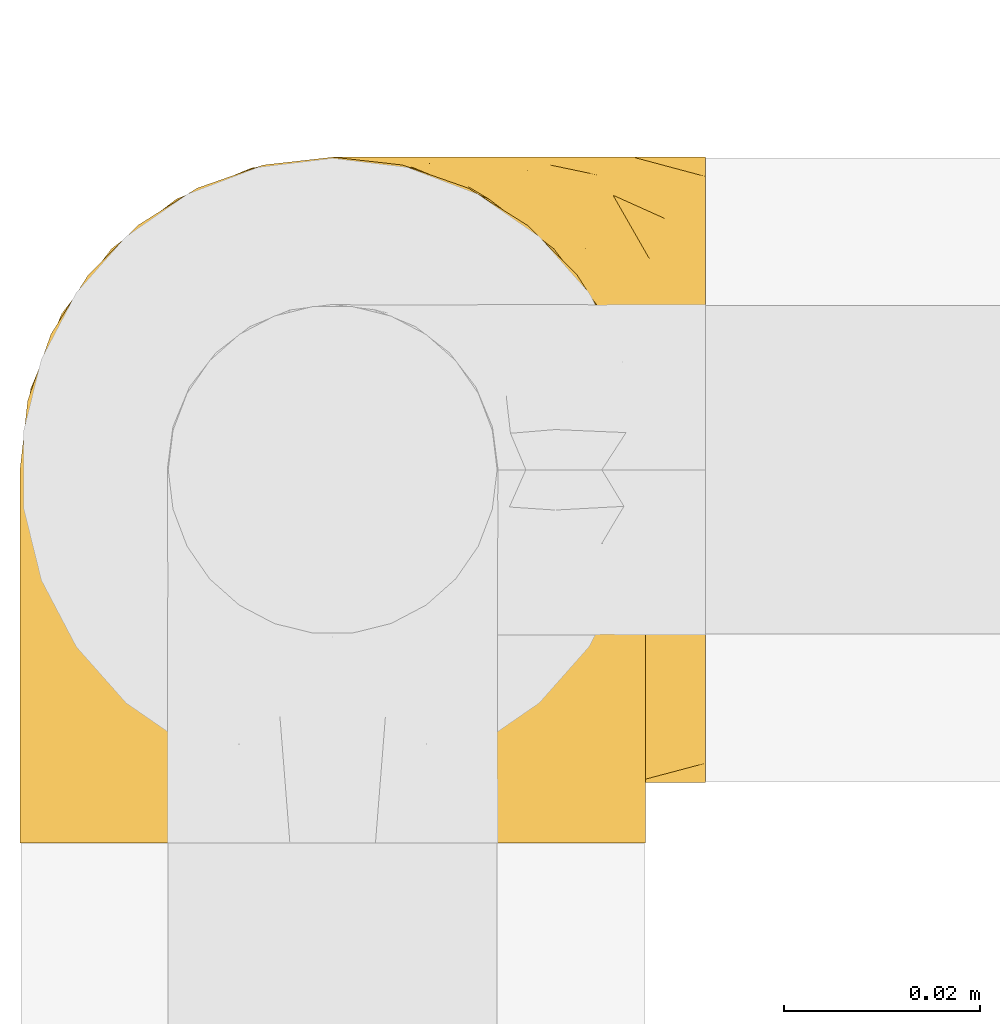
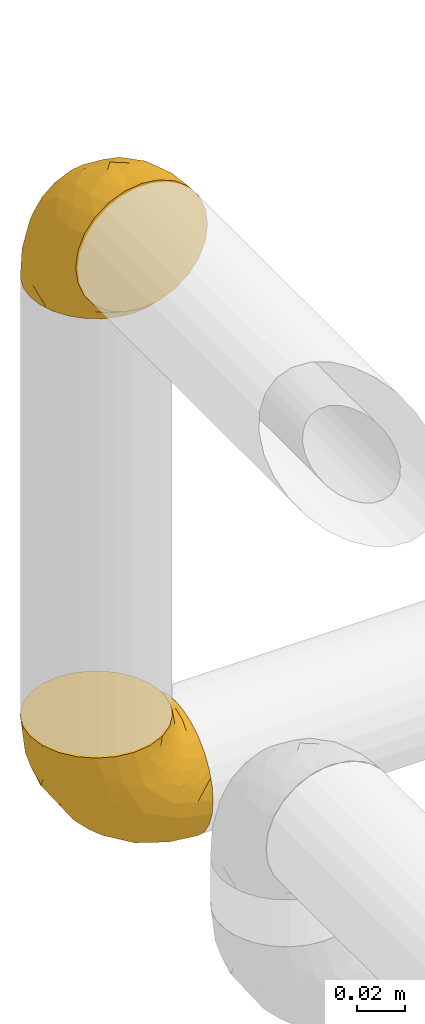
# One storey, part 11 of 39: 2 coverings.
"""IFC2X3 building model written with IfcOpenShell, lengths in millimetres."""

from ifc_helpers import new_model, entity, si_unit, converted_unit, derived_unit, direction, frame, origin, place, context, subcontext, project, spatial, faceted_brep, element, save


model = new_model("IFC2X3")

# Units and contexts
model_context = context("Model", 3, precision=0.01, world=origin(), true_north=direction((6.12303176911189e-17, 1.0)))
body_context = subcontext(model_context, "Body", "Model", "MODEL_VIEW")
ifc_project = project(units=[si_unit("LENGTHUNIT", "METRE", prefix="MILLI"), si_unit("AREAUNIT", "SQUARE_METRE"), si_unit("VOLUMEUNIT", "CUBIC_METRE"), converted_unit("PLANEANGLEUNIT", "DEGREE", entity("IfcRatioMeasure", 0.0174532925199433), si_unit("PLANEANGLEUNIT", "RADIAN"), dimensions=[0, 0, 0, 0, 0, 0, 0]), si_unit("MASSUNIT", "GRAM", prefix="KILO"), derived_unit("MASSDENSITYUNIT", [(si_unit("MASSUNIT", "GRAM", prefix="KILO"), 1), (si_unit("LENGTHUNIT", "METRE"), -3)]), derived_unit("MOMENTOFINERTIAUNIT", [(si_unit("LENGTHUNIT", "METRE"), 4)]), si_unit("TIMEUNIT", "SECOND"), si_unit("FREQUENCYUNIT", "HERTZ"), si_unit("THERMODYNAMICTEMPERATUREUNIT", "DEGREE_CELSIUS"), derived_unit("THERMALTRANSMITTANCEUNIT", [(si_unit("MASSUNIT", "GRAM", prefix="KILO"), 1), (si_unit("THERMODYNAMICTEMPERATUREUNIT", "KELVIN"), -1), (si_unit("TIMEUNIT", "SECOND"), -3)]), derived_unit("VOLUMETRICFLOWRATEUNIT", [(si_unit("LENGTHUNIT", "METRE"), 3), (si_unit("TIMEUNIT", "SECOND"), -1)]), derived_unit("MASSFLOWRATEUNIT", [(si_unit("MASSUNIT", "GRAM", prefix="KILO"), 1), (si_unit("TIMEUNIT", "SECOND"), -1)]), derived_unit("ROTATIONALFREQUENCYUNIT", [(si_unit("TIMEUNIT", "SECOND"), -1)]), si_unit("ELECTRICCURRENTUNIT", "AMPERE"), si_unit("ELECTRICVOLTAGEUNIT", "VOLT"), si_unit("POWERUNIT", "WATT"), si_unit("FORCEUNIT", "NEWTON", prefix="KILO"), si_unit("ILLUMINANCEUNIT", "LUX"), si_unit("LUMINOUSFLUXUNIT", "LUMEN"), si_unit("LUMINOUSINTENSITYUNIT", "CANDELA"), derived_unit("USERDEFINED", [(si_unit("MASSUNIT", "GRAM", prefix="KILO"), -1), (si_unit("LENGTHUNIT", "METRE"), -2), (si_unit("TIMEUNIT", "SECOND"), 3), (si_unit("LUMINOUSFLUXUNIT", "LUMEN"), 1)]), derived_unit("LINEARVELOCITYUNIT", [(si_unit("LENGTHUNIT", "METRE"), 1), (si_unit("TIMEUNIT", "SECOND"), -1)]), si_unit("PRESSUREUNIT", "PASCAL"), derived_unit("USERDEFINED", [(si_unit("LENGTHUNIT", "METRE"), -2), (si_unit("MASSUNIT", "GRAM", prefix="KILO"), 1), (si_unit("TIMEUNIT", "SECOND"), -2)]), derived_unit("LINEARFORCEUNIT", [(si_unit("MASSUNIT", "GRAM", prefix="KILO"), 1), (si_unit("LENGTHUNIT", "METRE"), 1), (si_unit("TIMEUNIT", "SECOND"), -2), (si_unit("LENGTHUNIT", "METRE"), -1)]), derived_unit("PLANARFORCEUNIT", [(si_unit("MASSUNIT", "GRAM", prefix="KILO"), 1), (si_unit("LENGTHUNIT", "METRE"), 1), (si_unit("TIMEUNIT", "SECOND"), -2), (si_unit("LENGTHUNIT", "METRE"), -2)])], contexts=[model_context])

# Site, building, storey
site_placement = place(None, origin())
site = spatial("IfcSite", under=ifc_project, at=site_placement, CompositionType="ELEMENT")
building_placement = place(site_placement, origin())
building = spatial("IfcBuilding", under=site, at=building_placement, CompositionType="ELEMENT")
storey_placement = place(building_placement, frame((0.0, 0.0, 24000.0)))
storey = spatial("IfcBuildingStorey", under=building, at=storey_placement, Name="07", CompositionType="ELEMENT", Elevation=24000.0)

# Coverings
covering_1_placement = place(storey_placement, frame((26666.66, 8370.36, 3460.4)))
element("IfcCovering", 1, at=covering_1_placement, inside=storey, Name=":ADSK_", ObjectType=":ADSK_", PredefinedType="INSULATION", context=body_context, shape_type="Brep", body=[
    faceted_brep([(26.36, 70.65, 1.6), (33.45, 71.45, 1.6), (40.54, 70.65, 1.6), (47.27, 68.29, 1.6), (53.31, 64.49, 1.6), (58.35, 59.45, 1.6), (62.14, 53.41, 1.6), (64.5, 46.68, 1.6), (65.3, 39.6, 1.6), (64.86, 35.69, 1.6), (64.5, 32.5, 1.6), (63.32, 29.14, 1.6), (62.14, 25.77, 1.6), (58.34, 19.73, 1.6), (53.3, 14.69, 1.6), (47.26, 10.9, 1.6), (40.53, 8.54, 1.6), (33.45, 7.75, 1.6), (26.35, 8.54, 1.6), (19.62, 10.9, 1.6), (13.58, 14.7, 1.6), (8.54, 19.74, 1.6), (4.75, 25.78, 1.6), (3.57, 29.15, 1.6), (2.39, 32.51, 1.6), (2.03, 35.69, 1.6), (1.81, 37.64, 1.6), (1.6, 39.6, 1.6), (2.39, 46.69, 1.6), (4.75, 53.42, 1.6), (8.55, 59.46, 1.6), (13.59, 64.5, 1.6), (19.63, 68.29, 1.6), (61.03, 1.6, 23.67), (62.62, 1.6, 27.51), (64.21, 1.6, 31.35), (64.78, 1.6, 35.67), (65.04, 1.6, 37.63), (65.3, 1.6, 39.6), (64.21, 1.6, 47.84), (61.03, 1.6, 55.52), (55.97, 1.6, 62.12), (49.37, 1.6, 67.18), (41.69, 1.6, 70.36), (33.45, 1.6, 71.45), (25.2, 1.6, 70.36), (17.52, 1.6, 67.18), (10.92, 1.6, 62.12), (5.86, 1.6, 55.52), (2.68, 1.6, 47.84), (1.6, 1.6, 39.6), (2.11, 1.6, 35.67), (2.68, 1.6, 31.35), (4.27, 1.6, 27.51), (5.86, 1.6, 23.67), (8.39, 1.6, 20.37), (10.92, 1.6, 17.07), (17.52, 1.6, 12.01), (25.2, 1.6, 8.83), (33.45, 1.6, 7.75), (41.69, 1.6, 8.83), (49.37, 1.6, 12.01), (55.97, 1.6, 17.07), (58.5, 1.6, 20.37), (2.87, 35.56, 33.94), (1.6, 34.5, 20.6), (1.6, 31.03, 24.07), (1.6, 27.55, 27.55), (1.6, 24.07, 31.03), (1.6, 20.6, 34.5), (33.45, 14.96, 68.79), (10.76, 32.2, 53.62), (5.89, 25.13, 50.17), (9.64, 17.37, 58.62), (22.45, 17.86, 67.51), (16.56, 27.91, 61.03), (15.17, 13.85, 64.5), (12.49, 61.37, 17.98), (25.02, 34.87, 61.71), (18.64, 44.22, 52.25), (2.29, 43.56, 16.72), (6.11, 40.93, 39.09), (5.18, 48.36, 25.86), (2.43, 17.22, 44.07), (11.11, 44.67, 44.36), (26.19, 63.86, 31.35), (24.02, 68.09, 17.72), (19.02, 61.87, 29.45), (4.77, 12.15, 52.37), (1.6, 17.69, 35.28), (1.6, 14.79, 36.06), (1.6, 11.89, 36.84), (1.6, 8.99, 37.61), (1.6, 7.14, 38.11), (1.6, 5.29, 38.61), (7.57, 56.77, 14.07), (17.54, 66.08, 13.65), (33.45, 68.79, 14.96), (4.36, 51.2, 13.32), (1.6, 39.1, 3.44), (1.6, 38.61, 5.29), (1.6, 37.61, 8.99), (1.6, 36.84, 11.89), (1.6, 36.06, 14.79), (1.6, 35.28, 17.69), (9.86, 54.2, 29.19), (14.05, 58.65, 28.91), (28.37, 21.36, 68.17), (33.45, 66.13, 28.33), (25.8, 46.99, 53.45), (33.45, 39.66, 58.56), (33.45, 50.99, 50.99), (22.54, 55.34, 43.14), (15.6, 53.83, 39.23), (33.45, 28.33, 66.13), (28.45, 55.34, 45.6), (33.45, 58.56, 39.66), (9.47, 6.06, 18.04), (5.83, 8.03, 22.76), (5.65, 11.06, 21.95), (2.31, 8.19, 32.18), (2.89, 10.89, 29.08), (2.68, 24.37, 20.77), (22.04, 9.23, 4.75), (5.47, 22.33, 11.03), (5.05, 24.59, 6.78), (7.86, 20.19, 5.68), (25.25, 5.45, 7.71), (28.09, 7.56, 4.42), (33.45, 5.94, 5.94), (12.77, 6.36, 14.52), (2.62, 29.84, 11.63), (3.56, 28.12, 6.6), (11.92, 14.94, 7.33), (11.98, 11.12, 12.48), (17.45, 9.87, 7.99), (17.1, 6.36, 11.14), (7.66, 16.34, 14.07), (4.47, 22.18, 15.37), (7.62, 18.62, 10.81), (2.29, 32.34, 7.89), (3.16, 15.29, 26.18), (16.64, 11.7, 5.8), (12.23, 13.14, 9.94), (4.54, 15.04, 22.23), (7.84, 10.61, 18.39), (2.55, 27.21, 17.71), (7.37, 14.05, 16.87), (3.18, 27.14, 13.24), (4.97, 5.74, 24.95), (2.38, 19.92, 26.59), (1.99, 23.61, 26.16), (3.56, 19.14, 22.11), (4.66, 20.12, 17.43), (44.85, 9.23, 4.75), (50.24, 11.69, 5.8), (49.43, 9.87, 7.99), (59.23, 16.33, 14.07), (54.76, 13.17, 10.06), (59.54, 18.65, 11.54), (41.64, 5.45, 7.71), (64.6, 32.33, 7.89), (65.3, 37.61, 8.99), (65.3, 36.84, 11.89), (65.3, 36.06, 14.79), (38.79, 7.56, 4.42), (62.38, 14.85, 22.42), (64.44, 17.26, 27.95), (61.27, 10.58, 22.22), (65.3, 3.44, 39.1), (65.3, 11.89, 36.84), (65.3, 8.99, 37.61), (65.3, 5.29, 38.61), (59.93, 5.65, 21.49), (62.73, 6.88, 26.52), (60.51, 14.93, 18.09), (59.05, 10.6, 18.39), (56.02, 11.09, 13.88), (49.79, 6.36, 11.14), (64.58, 8.19, 32.18), (65.3, 20.6, 34.5), (65.3, 24.07, 31.03), (64.27, 29.86, 11.65), (59.01, 20.16, 5.67), (61.84, 24.58, 6.81), (65.3, 38.61, 5.29), (65.3, 38.11, 7.14), (54.97, 14.93, 7.34), (65.3, 14.79, 36.06), (64.66, 12.32, 31.38), (63.94, 23.91, 19.83), (65.3, 27.55, 27.55), (63.6, 19.33, 22.94), (63.33, 28.11, 6.6), (57.32, 6.0, 17.93), (54.15, 6.44, 14.52), (64.5, 28.13, 17.45), (61.42, 22.32, 11.03), (65.3, 35.28, 17.69), (65.3, 34.5, 20.6), (63.43, 26.65, 12.33), (64.69, 15.34, 30.27), (65.3, 17.69, 35.28), (62.87, 10.31, 25.9), (65.3, 31.03, 24.07), (57.25, 17.37, 58.62), (62.54, 51.19, 13.32), (64.6, 43.56, 16.72), (64.46, 17.22, 44.07), (41.87, 34.87, 61.71), (44.44, 17.86, 67.51), (50.33, 27.92, 61.03), (61.0, 25.12, 50.18), (64.03, 35.57, 33.92), (60.79, 40.93, 39.08), (56.13, 32.19, 53.62), (38.52, 21.36, 68.17), (62.12, 12.15, 52.37), (51.72, 13.85, 64.5), (61.71, 48.35, 25.86), (59.33, 56.76, 14.07), (57.04, 54.19, 29.18), (47.88, 61.86, 29.46), (42.88, 68.09, 17.73), (40.71, 63.85, 31.37), (54.41, 61.36, 17.99), (41.09, 47.0, 53.45), (51.29, 53.81, 39.25), (52.85, 58.64, 28.92), (49.36, 66.07, 13.65), (48.25, 44.24, 52.23), (44.35, 55.34, 43.13), (55.79, 44.67, 44.36), (38.44, 55.34, 45.6)], [[[0, 1, 2, 3, 4, 5, 6, 7, 8, 9, 10, 11, 12, 13, 14, 15, 16, 17, 18, 19, 20, 21, 22, 23, 24, 25, 26, 27, 28, 29, 30, 31, 32]], [[33, 34, 35, 36, 37, 38, 39, 40, 41, 42, 43, 44, 45, 46, 47, 48, 49, 50, 51, 52, 53, 54, 55, 56, 57, 58, 59, 60, 61, 62, 63]], [[64, 65, 66, 67, 68, 69]], [[45, 44, 70]], [[71, 72, 73]], [[74, 75, 76]], [[77, 31, 30]], [[75, 78, 79]], [[27, 80, 28]], [[74, 46, 45]], [[64, 81, 82]], [[46, 76, 47]], [[83, 50, 49]], [[48, 47, 73]], [[71, 79, 84]], [[85, 86, 87]], [[49, 48, 88]], [[83, 69, 89, 90, 91, 92, 93, 94, 50]], [[95, 77, 30]], [[75, 74, 78]], [[87, 86, 96]], [[96, 86, 32]], [[96, 32, 31]], [[0, 86, 97]], [[83, 64, 69]], [[98, 80, 82]], [[73, 72, 88]], [[64, 80, 65]], [[1, 0, 97]], [[80, 27, 99, 100, 101, 102, 103, 104, 65]], [[77, 105, 106]], [[64, 82, 80]], [[70, 107, 45]], [[77, 95, 105]], [[82, 95, 98]], [[95, 30, 29]], [[74, 107, 78]], [[86, 0, 32]], [[72, 71, 81]], [[85, 108, 86]], [[76, 73, 47]], [[71, 84, 81]], [[109, 110, 111]], [[87, 112, 85]], [[79, 109, 112]], [[79, 112, 113]], [[88, 83, 49]], [[64, 83, 72]], [[31, 77, 96]], [[87, 96, 77]], [[98, 95, 29]], [[105, 95, 82]], [[81, 105, 82]], [[105, 84, 113]], [[29, 28, 98]], [[114, 107, 70]], [[80, 98, 28]], [[73, 75, 71]], [[79, 71, 75]], [[74, 76, 46]], [[73, 76, 75]], [[78, 107, 114]], [[45, 107, 74]], [[87, 113, 112]], [[115, 85, 112]], [[109, 79, 78]], [[113, 87, 106]], [[116, 115, 111]], [[116, 108, 85]], [[79, 113, 84]], [[109, 78, 110]], [[115, 109, 111]], [[85, 115, 116]], [[109, 115, 112]], [[72, 81, 64]], [[105, 81, 84]], [[73, 88, 48]], [[83, 88, 72]], [[86, 108, 97]], [[78, 114, 110]], [[113, 106, 105]], [[87, 77, 106]], [[117, 118, 119]], [[52, 120, 54, 53]], [[91, 120, 52]], [[91, 90, 120]], [[90, 121, 120]], [[122, 67, 66]], [[18, 123, 19]], [[124, 125, 126]], [[127, 59, 58]], [[128, 129, 127]], [[130, 57, 117]], [[131, 132, 125]], [[19, 133, 20]], [[128, 18, 17]], [[134, 135, 136]], [[137, 138, 139]], [[131, 103, 140]], [[22, 140, 23]], [[131, 65, 104, 103]], [[99, 27, 26, 25, 24, 101, 100]], [[141, 118, 121]], [[19, 123, 142]], [[52, 51, 50, 94, 93, 92, 91]], [[129, 128, 17]], [[117, 56, 118]], [[135, 134, 143]], [[139, 126, 133]], [[119, 144, 145]], [[127, 135, 123]], [[136, 58, 57]], [[101, 24, 23]], [[124, 138, 146]], [[140, 101, 23]], [[145, 147, 134]], [[140, 132, 131]], [[140, 103, 102, 101]], [[140, 22, 132]], [[146, 148, 124]], [[121, 69, 141]], [[55, 149, 118]], [[150, 151, 152]], [[147, 137, 134]], [[144, 150, 152]], [[152, 151, 122]], [[138, 122, 146]], [[59, 127, 129]], [[123, 18, 128]], [[58, 136, 127]], [[135, 127, 136]], [[121, 90, 89, 69]], [[120, 121, 149]], [[122, 66, 146]], [[153, 122, 138]], [[141, 69, 68]], [[127, 123, 128]], [[123, 135, 142]], [[143, 142, 135]], [[19, 142, 133]], [[66, 65, 146]], [[148, 65, 131]], [[22, 21, 132]], [[125, 132, 21]], [[126, 125, 21]], [[148, 125, 124]], [[21, 20, 126]], [[133, 126, 20]], [[139, 138, 124]], [[153, 138, 137]], [[126, 139, 124]], [[139, 133, 143]], [[147, 153, 137]], [[152, 122, 153]], [[134, 136, 130]], [[137, 139, 143]], [[144, 147, 145]], [[153, 147, 152]], [[65, 148, 146]], [[125, 148, 131]], [[141, 144, 119]], [[55, 54, 149]], [[137, 143, 134]], [[142, 143, 133]], [[130, 117, 145]], [[57, 56, 117]], [[134, 130, 145]], [[57, 130, 136]], [[150, 144, 141]], [[147, 144, 152]], [[141, 68, 150]], [[151, 68, 67]], [[117, 119, 145]], [[141, 119, 118]], [[68, 151, 150]], [[122, 151, 67]], [[118, 56, 55]], [[120, 149, 54]], [[118, 149, 121]], [[154, 155, 156]], [[157, 158, 159]], [[129, 160, 59]], [[161, 162, 163, 164]], [[165, 160, 129]], [[166, 167, 168]], [[169, 38, 37, 36, 35, 170, 171, 172]], [[63, 173, 174]], [[175, 176, 177]], [[60, 178, 61]], [[179, 35, 34, 33]], [[160, 60, 59]], [[180, 167, 181]], [[129, 17, 165]], [[182, 161, 164]], [[183, 13, 184]], [[9, 8, 185, 186, 162, 10]], [[187, 155, 15]], [[188, 179, 189]], [[187, 15, 14]], [[190, 191, 192]], [[182, 193, 161]], [[194, 176, 168]], [[176, 195, 177]], [[196, 190, 197]], [[11, 10, 162]], [[11, 161, 12]], [[187, 14, 183]], [[12, 161, 193]], [[156, 158, 177]], [[165, 17, 16]], [[194, 195, 176]], [[187, 159, 158]], [[179, 174, 189]], [[182, 164, 198, 199]], [[200, 199, 196]], [[193, 184, 13]], [[194, 168, 173]], [[201, 202, 189]], [[16, 154, 165]], [[160, 156, 178]], [[160, 165, 154]], [[178, 60, 160]], [[170, 35, 179]], [[188, 170, 179]], [[189, 174, 203]], [[174, 179, 33]], [[201, 189, 203]], [[181, 192, 191]], [[167, 180, 201]], [[192, 175, 190]], [[159, 190, 157]], [[15, 154, 16]], [[204, 196, 199]], [[204, 191, 190]], [[160, 154, 156]], [[15, 155, 154]], [[158, 155, 187]], [[203, 173, 168]], [[192, 181, 167]], [[190, 196, 204]], [[200, 196, 197]], [[184, 193, 182]], [[13, 12, 193]], [[200, 184, 182]], [[184, 200, 183]], [[187, 183, 197]], [[14, 13, 183]], [[162, 161, 11]], [[63, 62, 173]], [[174, 33, 63]], [[173, 62, 194]], [[174, 173, 203]], [[62, 61, 194]], [[195, 61, 178]], [[61, 195, 194]], [[177, 195, 178]], [[156, 177, 178]], [[175, 192, 166]], [[166, 168, 176]], [[167, 203, 168]], [[175, 166, 176]], [[167, 166, 192]], [[177, 157, 175]], [[190, 175, 157]], [[187, 197, 159]], [[190, 159, 197]], [[177, 158, 157]], [[155, 158, 156]], [[167, 201, 203]], [[200, 197, 183]], [[202, 201, 180]], [[202, 188, 189]], [[199, 200, 182]], [[41, 40, 205]], [[206, 207, 7]], [[208, 38, 169, 172, 171, 170, 188, 202, 180]], [[209, 210, 211]], [[212, 213, 214]], [[212, 215, 205]], [[43, 210, 216]], [[217, 40, 39]], [[216, 114, 70]], [[208, 213, 212]], [[205, 40, 217]], [[218, 42, 41]], [[216, 209, 114]], [[42, 218, 210]], [[214, 213, 219]], [[219, 220, 221]], [[199, 207, 213]], [[213, 207, 219]], [[8, 7, 207]], [[222, 223, 224]], [[4, 225, 5]], [[2, 97, 223]], [[110, 226, 111]], [[225, 220, 5]], [[227, 221, 228]], [[223, 229, 3]], [[2, 223, 3]], [[230, 231, 226]], [[224, 223, 108]], [[42, 210, 43]], [[230, 209, 211]], [[222, 225, 229]], [[38, 208, 39]], [[3, 229, 4]], [[213, 180, 181, 191, 204, 199]], [[220, 206, 6]], [[5, 220, 6]], [[207, 199, 198, 164, 163, 162, 186, 185, 8]], [[212, 214, 215]], [[218, 205, 211]], [[211, 215, 230]], [[226, 110, 209]], [[222, 231, 227]], [[222, 224, 231]], [[213, 208, 180]], [[217, 208, 212]], [[222, 229, 223]], [[225, 4, 229]], [[221, 220, 225]], [[206, 220, 219]], [[228, 221, 225]], [[214, 221, 232]], [[207, 206, 219]], [[44, 43, 70]], [[7, 6, 206]], [[230, 215, 232]], [[211, 205, 215]], [[205, 218, 41]], [[210, 218, 211]], [[43, 216, 70]], [[209, 216, 210]], [[233, 116, 111]], [[230, 232, 227]], [[224, 116, 233]], [[230, 226, 209]], [[224, 108, 116]], [[230, 227, 231]], [[221, 227, 232]], [[233, 226, 231]], [[225, 222, 228]], [[226, 233, 111]], [[224, 233, 231]], [[221, 214, 219]], [[214, 232, 215]], [[208, 217, 39]], [[205, 217, 212]], [[97, 2, 1]], [[97, 108, 223]], [[110, 114, 209]], [[227, 228, 222]]]),
])
covering_2_placement = place(storey_placement, frame((26666.66, 8376.51, 3166.55)))
element("IfcCovering", 2, at=covering_2_placement, inside=storey, Name=":ADSK_", ObjectType=":ADSK_", PredefinedType="INSULATION", context=body_context, shape_type="Brep", body=[
    faceted_brep([(71.45, 26.36, 2.39), (71.45, 33.45, 1.6), (71.45, 40.54, 2.39), (71.45, 47.27, 4.75), (71.45, 53.31, 8.55), (71.45, 58.35, 13.59), (71.45, 62.14, 19.63), (71.45, 64.5, 26.36), (71.45, 65.3, 33.45), (71.45, 64.86, 37.35), (71.45, 64.5, 40.54), (71.45, 63.32, 43.9), (71.45, 62.14, 47.27), (71.45, 58.34, 53.31), (71.45, 53.3, 58.35), (71.45, 47.26, 62.14), (71.45, 40.53, 64.5), (71.45, 33.45, 65.3), (71.45, 26.35, 64.5), (71.45, 19.62, 62.14), (71.45, 13.58, 58.34), (71.45, 8.54, 53.3), (71.45, 4.75, 47.26), (71.45, 3.57, 43.89), (71.45, 2.39, 40.53), (71.45, 2.03, 37.35), (71.45, 1.81, 35.4), (71.45, 1.6, 33.45), (71.45, 2.39, 26.35), (71.45, 4.75, 19.62), (71.45, 8.55, 13.58), (71.45, 13.59, 8.54), (71.45, 19.63, 4.75), (49.37, 61.03, 71.45), (45.53, 62.62, 71.45), (41.69, 64.21, 71.45), (37.37, 64.78, 71.45), (35.41, 65.04, 71.45), (33.45, 65.3, 71.45), (25.2, 64.21, 71.45), (17.52, 61.03, 71.45), (10.92, 55.97, 71.45), (5.86, 49.37, 71.45), (2.68, 41.69, 71.45), (1.6, 33.45, 71.45), (2.68, 25.2, 71.45), (5.86, 17.52, 71.45), (10.92, 10.92, 71.45), (17.52, 5.86, 71.45), (25.2, 2.68, 71.45), (33.45, 1.6, 71.45), (37.37, 2.11, 71.45), (41.69, 2.68, 71.45), (45.53, 4.27, 71.45), (49.37, 5.86, 71.45), (52.67, 8.39, 71.45), (55.97, 10.92, 71.45), (61.03, 17.52, 71.45), (64.21, 25.2, 71.45), (65.3, 33.45, 71.45), (64.21, 41.69, 71.45), (61.03, 49.37, 71.45), (55.97, 55.97, 71.45), (52.67, 58.5, 71.45), (39.1, 2.87, 37.48), (52.45, 1.6, 38.54), (48.97, 1.6, 42.01), (45.49, 1.6, 45.49), (42.01, 1.6, 48.97), (38.54, 1.6, 52.45), (4.25, 33.45, 58.08), (19.42, 10.76, 40.84), (22.87, 5.89, 47.91), (14.43, 9.64, 55.67), (5.53, 22.45, 55.18), (12.01, 16.56, 45.13), (8.54, 15.17, 59.19), (55.06, 12.49, 11.67), (11.33, 25.02, 38.17), (20.79, 18.64, 28.82), (56.32, 2.29, 29.48), (33.95, 6.11, 32.11), (47.18, 5.18, 24.68), (28.97, 2.43, 55.82), (28.68, 11.11, 28.37), (41.69, 26.19, 9.18), (55.32, 24.02, 4.95), (43.59, 19.02, 11.17), (20.67, 4.77, 60.89), (37.76, 1.6, 55.35), (36.98, 1.6, 58.25), (36.2, 1.6, 61.15), (35.43, 1.6, 64.05), (34.93, 1.6, 65.9), (34.44, 1.6, 67.75), (58.97, 7.57, 16.27), (59.39, 17.54, 6.97), (58.08, 33.45, 4.25), (59.72, 4.36, 21.84), (69.6, 1.6, 33.94), (67.75, 1.6, 34.44), (64.05, 1.6, 35.43), (61.15, 1.6, 36.2), (58.25, 1.6, 36.98), (55.35, 1.6, 37.76), (43.85, 9.86, 18.84), (44.13, 14.05, 14.39), (4.87, 28.37, 51.68), (44.71, 33.45, 6.91), (19.59, 25.8, 26.05), (14.48, 33.45, 33.38), (22.05, 33.45, 22.05), (29.9, 22.54, 17.7), (33.81, 15.6, 19.21), (6.91, 33.45, 44.71), (27.44, 28.45, 17.7), (33.38, 33.45, 14.48), (55.01, 9.47, 66.98), (50.28, 5.83, 65.01), (51.09, 5.65, 61.98), (40.86, 2.31, 64.85), (43.96, 2.89, 62.15), (52.27, 2.68, 48.67), (68.29, 22.04, 63.81), (62.01, 5.47, 50.71), (66.26, 5.05, 48.45), (67.36, 7.86, 52.85), (65.34, 25.25, 67.6), (68.62, 28.09, 65.48), (67.1, 33.45, 67.1), (58.52, 12.77, 66.68), (61.41, 2.62, 43.2), (66.44, 3.56, 44.92), (65.71, 11.92, 58.1), (60.56, 11.98, 61.92), (65.05, 17.45, 63.17), (61.9, 17.1, 66.68), (58.97, 7.66, 56.7), (57.67, 4.47, 50.86), (62.23, 7.62, 54.42), (65.15, 2.29, 40.7), (46.86, 3.16, 57.76), (67.24, 16.64, 61.34), (63.1, 12.23, 59.9), (50.81, 4.54, 58.0), (54.65, 7.84, 62.43), (55.33, 2.55, 45.83), (56.17, 7.37, 58.99), (59.8, 3.18, 45.9), (48.09, 4.97, 67.3), (46.45, 2.38, 53.12), (46.88, 1.99, 49.43), (50.93, 3.56, 53.9), (55.61, 4.66, 52.92), (68.29, 44.85, 63.81), (67.24, 50.24, 61.35), (65.05, 49.43, 63.17), (58.97, 59.23, 56.72), (62.98, 54.76, 59.87), (61.5, 59.54, 54.39), (65.34, 41.64, 67.59), (65.15, 64.6, 40.71), (64.05, 65.3, 35.43), (61.15, 65.3, 36.2), (58.25, 65.3, 36.98), (68.62, 38.79, 65.48), (50.62, 62.38, 58.19), (45.09, 64.44, 55.78), (50.82, 61.27, 62.46), (33.94, 65.3, 69.6), (36.2, 65.3, 61.15), (35.43, 65.3, 64.05), (34.44, 65.3, 67.75), (51.55, 59.93, 67.39), (46.52, 62.73, 66.16), (54.95, 60.51, 58.11), (54.65, 59.05, 62.44), (59.16, 56.02, 61.95), (61.9, 49.79, 66.68), (40.86, 64.58, 64.85), (38.54, 65.3, 52.45), (42.01, 65.3, 48.97), (61.39, 64.27, 43.18), (67.37, 59.01, 52.88), (66.23, 61.84, 48.46), (67.75, 65.3, 34.44), (65.9, 65.3, 34.93), (65.7, 54.97, 58.11), (36.98, 65.3, 58.25), (41.66, 64.66, 60.72), (53.21, 63.94, 49.13), (45.49, 65.3, 45.49), (50.1, 63.6, 53.71), (66.44, 63.33, 44.93), (55.11, 57.32, 67.04), (58.52, 54.15, 66.6), (55.59, 64.5, 44.91), (62.01, 61.42, 50.72), (55.35, 65.3, 37.76), (52.45, 65.3, 38.54), (60.71, 63.43, 46.39), (47.15, 62.87, 62.73), (42.77, 64.69, 57.7), (37.76, 65.3, 55.35), (48.97, 65.3, 42.01), (14.42, 57.25, 55.67), (59.72, 62.54, 21.85), (56.32, 64.6, 29.49), (28.97, 64.46, 55.82), (11.33, 41.87, 38.17), (5.53, 44.44, 55.18), (12.01, 50.33, 45.12), (22.86, 61.0, 47.92), (39.12, 64.03, 37.47), (33.96, 60.79, 32.11), (19.42, 56.13, 40.85), (4.87, 38.52, 51.68), (20.67, 62.12, 60.89), (8.55, 51.72, 59.19), (47.18, 61.71, 24.69), (58.97, 59.33, 16.28), (43.86, 57.04, 18.85), (43.58, 47.88, 11.19), (55.32, 42.88, 4.95), (41.67, 40.71, 9.19), (55.05, 54.41, 11.68), (19.59, 41.09, 26.05), (33.79, 51.29, 19.23), (44.12, 52.85, 14.4), (59.39, 49.36, 6.97), (20.81, 48.25, 28.8), (29.91, 44.35, 17.7), (28.68, 55.79, 28.37), (27.45, 38.44, 17.7)], [[[0, 1, 2, 3, 4, 5, 6, 7, 8, 9, 10, 11, 12, 13, 14, 15, 16, 17, 18, 19, 20, 21, 22, 23, 24, 25, 26, 27, 28, 29, 30, 31, 32]], [[33, 34, 35, 36, 37, 38, 39, 40, 41, 42, 43, 44, 45, 46, 47, 48, 49, 50, 51, 52, 53, 54, 55, 56, 57, 58, 59, 60, 61, 62, 63]], [[64, 65, 66, 67, 68, 69]], [[45, 44, 70]], [[71, 72, 73]], [[74, 75, 76]], [[77, 31, 30]], [[75, 78, 79]], [[27, 80, 28]], [[74, 46, 45]], [[64, 81, 82]], [[46, 76, 47]], [[83, 50, 49]], [[48, 47, 73]], [[71, 79, 84]], [[85, 86, 87]], [[49, 48, 88]], [[83, 69, 89, 90, 91, 92, 93, 94, 50]], [[95, 77, 30]], [[75, 74, 78]], [[87, 86, 96]], [[96, 86, 32]], [[96, 32, 31]], [[0, 86, 97]], [[83, 64, 69]], [[98, 80, 82]], [[73, 72, 88]], [[64, 80, 65]], [[1, 0, 97]], [[80, 27, 99, 100, 101, 102, 103, 104, 65]], [[77, 105, 106]], [[64, 82, 80]], [[70, 107, 45]], [[77, 95, 105]], [[82, 95, 98]], [[95, 30, 29]], [[74, 107, 78]], [[86, 0, 32]], [[72, 71, 81]], [[85, 108, 86]], [[76, 73, 47]], [[71, 84, 81]], [[109, 110, 111]], [[87, 112, 85]], [[79, 109, 112]], [[79, 112, 113]], [[88, 83, 49]], [[64, 83, 72]], [[31, 77, 96]], [[87, 96, 77]], [[98, 95, 29]], [[105, 95, 82]], [[81, 105, 82]], [[105, 84, 113]], [[29, 28, 98]], [[114, 107, 70]], [[80, 98, 28]], [[73, 75, 71]], [[79, 71, 75]], [[74, 76, 46]], [[73, 76, 75]], [[78, 107, 114]], [[45, 107, 74]], [[87, 113, 112]], [[115, 85, 112]], [[109, 79, 78]], [[113, 87, 106]], [[116, 115, 111]], [[116, 108, 85]], [[79, 113, 84]], [[109, 78, 110]], [[115, 109, 111]], [[85, 115, 116]], [[109, 115, 112]], [[72, 81, 64]], [[105, 81, 84]], [[73, 88, 48]], [[83, 88, 72]], [[86, 108, 97]], [[78, 114, 110]], [[113, 106, 105]], [[87, 77, 106]], [[117, 118, 119]], [[52, 120, 54, 53]], [[91, 120, 52]], [[91, 90, 120]], [[90, 121, 120]], [[122, 67, 66]], [[18, 123, 19]], [[124, 125, 126]], [[127, 59, 58]], [[128, 129, 127]], [[130, 57, 117]], [[131, 132, 125]], [[19, 133, 20]], [[128, 18, 17]], [[134, 135, 136]], [[137, 138, 139]], [[131, 103, 140]], [[22, 140, 23]], [[131, 65, 104, 103]], [[99, 27, 26, 25, 24, 101, 100]], [[141, 118, 121]], [[19, 123, 142]], [[52, 51, 50, 94, 93, 92, 91]], [[129, 128, 17]], [[117, 56, 118]], [[135, 134, 143]], [[139, 126, 133]], [[119, 144, 145]], [[127, 135, 123]], [[136, 58, 57]], [[101, 24, 23]], [[124, 138, 146]], [[140, 101, 23]], [[145, 147, 134]], [[140, 132, 131]], [[140, 103, 102, 101]], [[140, 22, 132]], [[146, 148, 124]], [[121, 69, 141]], [[55, 149, 118]], [[150, 151, 152]], [[147, 137, 134]], [[144, 150, 152]], [[152, 151, 122]], [[138, 122, 146]], [[59, 127, 129]], [[123, 18, 128]], [[58, 136, 127]], [[135, 127, 136]], [[121, 90, 89, 69]], [[120, 121, 149]], [[122, 66, 146]], [[153, 122, 138]], [[141, 69, 68]], [[127, 123, 128]], [[123, 135, 142]], [[143, 142, 135]], [[19, 142, 133]], [[66, 65, 146]], [[148, 65, 131]], [[22, 21, 132]], [[125, 132, 21]], [[126, 125, 21]], [[148, 125, 124]], [[21, 20, 126]], [[133, 126, 20]], [[139, 138, 124]], [[153, 138, 137]], [[126, 139, 124]], [[139, 133, 143]], [[147, 153, 137]], [[152, 122, 153]], [[134, 136, 130]], [[137, 139, 143]], [[144, 147, 145]], [[153, 147, 152]], [[65, 148, 146]], [[125, 148, 131]], [[141, 144, 119]], [[55, 54, 149]], [[137, 143, 134]], [[142, 143, 133]], [[130, 117, 145]], [[57, 56, 117]], [[134, 130, 145]], [[57, 130, 136]], [[150, 144, 141]], [[147, 144, 152]], [[141, 68, 150]], [[151, 68, 67]], [[117, 119, 145]], [[141, 119, 118]], [[68, 151, 150]], [[122, 151, 67]], [[118, 56, 55]], [[120, 149, 54]], [[118, 149, 121]], [[154, 155, 156]], [[157, 158, 159]], [[129, 160, 59]], [[161, 162, 163, 164]], [[165, 160, 129]], [[166, 167, 168]], [[169, 38, 37, 36, 35, 170, 171, 172]], [[63, 173, 174]], [[175, 176, 177]], [[60, 178, 61]], [[179, 35, 34, 33]], [[160, 60, 59]], [[180, 167, 181]], [[129, 17, 165]], [[182, 161, 164]], [[183, 13, 184]], [[9, 8, 185, 186, 162, 10]], [[187, 155, 15]], [[188, 179, 189]], [[187, 15, 14]], [[190, 191, 192]], [[182, 193, 161]], [[194, 176, 168]], [[176, 195, 177]], [[196, 190, 197]], [[11, 10, 162]], [[11, 161, 12]], [[187, 14, 183]], [[12, 161, 193]], [[156, 158, 177]], [[165, 17, 16]], [[194, 195, 176]], [[187, 159, 158]], [[179, 174, 189]], [[182, 164, 198, 199]], [[200, 199, 196]], [[193, 184, 13]], [[174, 173, 201]], [[202, 203, 189]], [[16, 154, 165]], [[160, 156, 178]], [[160, 165, 154]], [[178, 60, 160]], [[170, 35, 179]], [[188, 170, 179]], [[189, 174, 201]], [[174, 179, 33]], [[202, 189, 201]], [[181, 192, 191]], [[167, 180, 202]], [[192, 175, 190]], [[159, 190, 157]], [[15, 154, 16]], [[204, 196, 199]], [[204, 191, 190]], [[160, 154, 156]], [[15, 155, 154]], [[158, 155, 187]], [[201, 173, 168]], [[192, 181, 167]], [[190, 196, 204]], [[200, 196, 197]], [[184, 193, 182]], [[13, 12, 193]], [[200, 184, 182]], [[184, 200, 183]], [[187, 183, 197]], [[14, 13, 183]], [[162, 161, 11]], [[62, 173, 63]], [[174, 33, 63]], [[194, 173, 62]], [[173, 194, 168]], [[62, 61, 194]], [[195, 61, 178]], [[61, 195, 194]], [[177, 195, 178]], [[156, 177, 178]], [[175, 192, 166]], [[166, 168, 176]], [[167, 201, 168]], [[175, 166, 176]], [[167, 166, 192]], [[177, 157, 175]], [[190, 175, 157]], [[187, 197, 159]], [[190, 159, 197]], [[177, 158, 157]], [[155, 158, 156]], [[167, 202, 201]], [[200, 197, 183]], [[203, 202, 180]], [[203, 188, 189]], [[199, 200, 182]], [[41, 40, 205]], [[206, 207, 7]], [[208, 38, 169, 172, 171, 170, 188, 203, 180]], [[209, 210, 211]], [[212, 213, 214]], [[212, 215, 205]], [[43, 210, 216]], [[217, 40, 39]], [[216, 114, 70]], [[208, 213, 212]], [[205, 40, 217]], [[218, 42, 41]], [[216, 209, 114]], [[42, 218, 210]], [[214, 213, 219]], [[219, 220, 221]], [[199, 207, 213]], [[213, 207, 219]], [[8, 7, 207]], [[222, 223, 224]], [[4, 225, 5]], [[2, 97, 223]], [[110, 226, 111]], [[225, 220, 5]], [[227, 221, 228]], [[223, 229, 3]], [[2, 223, 3]], [[230, 231, 226]], [[224, 223, 108]], [[42, 210, 43]], [[230, 209, 211]], [[222, 225, 229]], [[38, 208, 39]], [[3, 229, 4]], [[213, 180, 181, 191, 204, 199]], [[220, 206, 6]], [[5, 220, 6]], [[207, 199, 198, 164, 163, 162, 186, 185, 8]], [[212, 214, 215]], [[218, 205, 211]], [[211, 215, 230]], [[226, 110, 209]], [[222, 231, 227]], [[222, 224, 231]], [[213, 208, 180]], [[217, 208, 212]], [[222, 229, 223]], [[225, 4, 229]], [[221, 220, 225]], [[206, 220, 219]], [[228, 221, 225]], [[214, 221, 232]], [[207, 206, 219]], [[44, 43, 70]], [[7, 6, 206]], [[230, 215, 232]], [[211, 205, 215]], [[205, 218, 41]], [[210, 218, 211]], [[43, 216, 70]], [[209, 216, 210]], [[233, 116, 111]], [[230, 232, 227]], [[224, 116, 233]], [[230, 226, 209]], [[224, 108, 116]], [[230, 227, 231]], [[221, 227, 232]], [[233, 226, 231]], [[225, 222, 228]], [[226, 233, 111]], [[224, 233, 231]], [[221, 214, 219]], [[214, 232, 215]], [[208, 217, 39]], [[205, 217, 212]], [[97, 2, 1]], [[97, 108, 223]], [[110, 114, 209]], [[227, 228, 222]]]),
])

save(model, "model.ifc")
